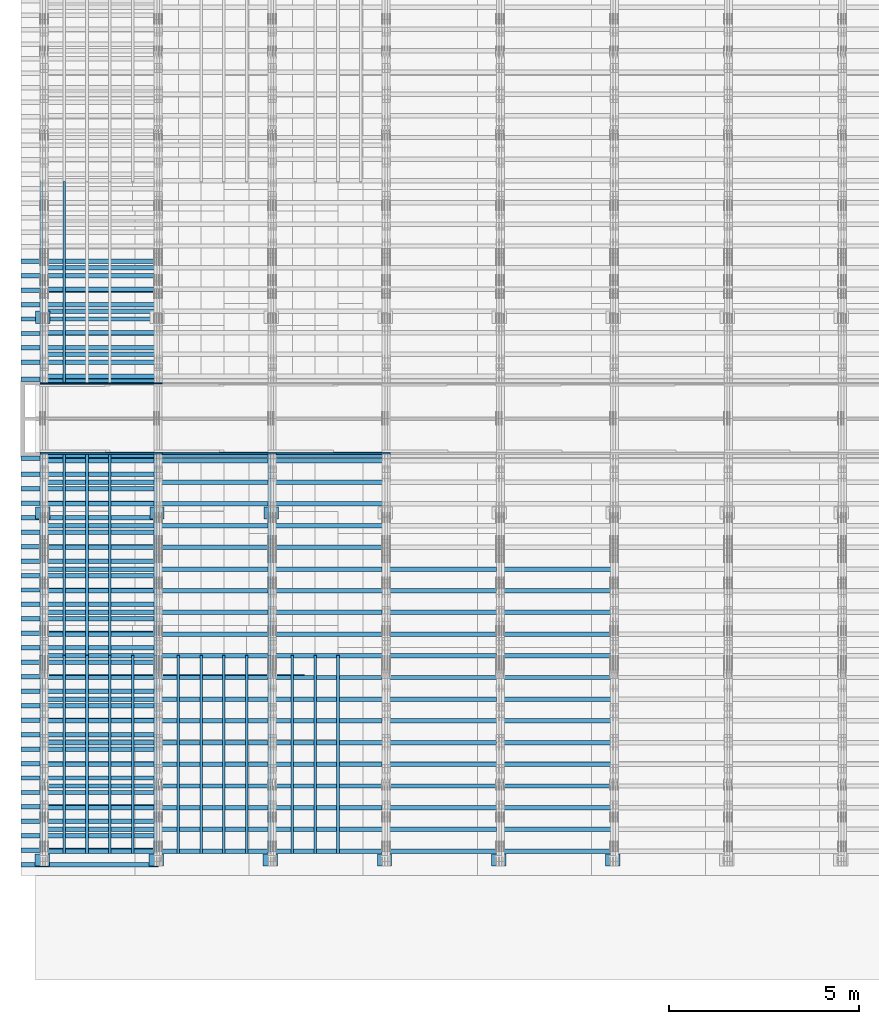
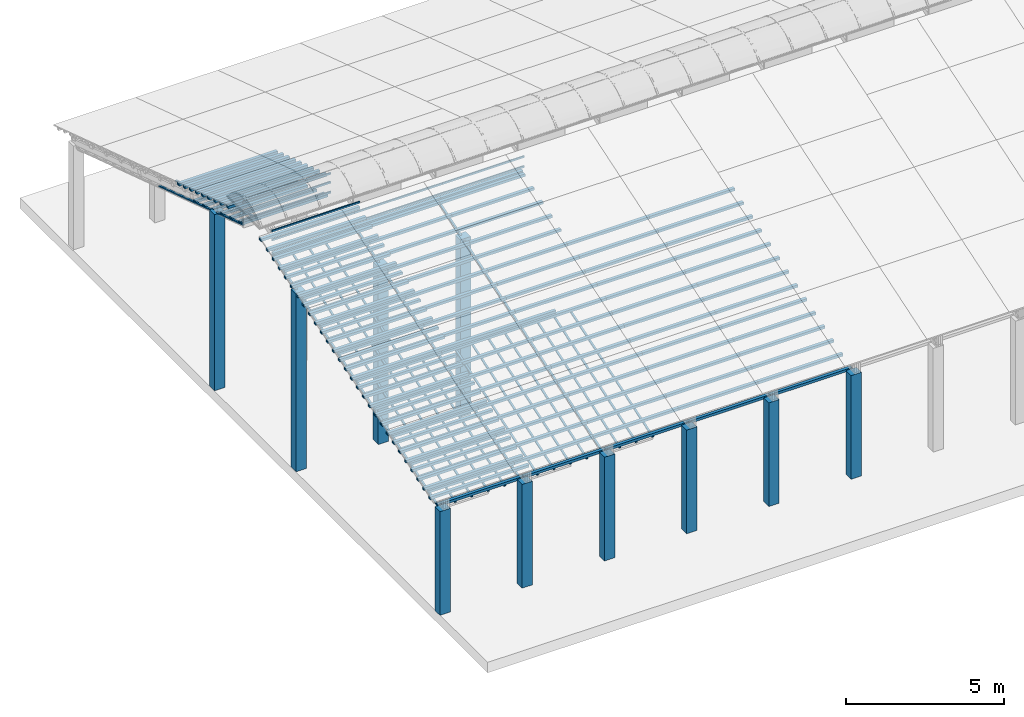
# One storey, part 1 of 385: 175 columns.
"""IFC2X3 building model written with IfcOpenShell, lengths in millimetres."""

from ifc_helpers import new_model, entity, si_unit, converted_unit, derived_unit, direction, frame, frame_2d, origin, origin_2d_with_axis, place, context, subcontext, project, spatial, rectangle, extrude, boolean, source, transform, mapped, material, type_object, type_shapes, element, save


model = new_model("IFC2X3")

# Units and contexts
model_context = context("Model", 3, precision=0.01, world=origin(), true_north=direction((6.12303176911189e-17, 1.0)))
body_context = subcontext(model_context, "Body", "Model", "MODEL_VIEW")
ifc_project = project(units=[si_unit("LENGTHUNIT", "METRE", prefix="MILLI"), si_unit("AREAUNIT", "SQUARE_METRE"), si_unit("VOLUMEUNIT", "CUBIC_METRE"), converted_unit("PLANEANGLEUNIT", "DEGREE", entity("IfcRatioMeasure", 0.0174532925199433), si_unit("PLANEANGLEUNIT", "RADIAN"), dimensions=[0, 0, 0, 0, 0, 0, 0]), si_unit("MASSUNIT", "GRAM", prefix="KILO"), derived_unit("MASSDENSITYUNIT", [(si_unit("MASSUNIT", "GRAM", prefix="KILO"), 1), (si_unit("LENGTHUNIT", "METRE"), -3)]), si_unit("TIMEUNIT", "SECOND"), si_unit("FREQUENCYUNIT", "HERTZ"), si_unit("THERMODYNAMICTEMPERATUREUNIT", "DEGREE_CELSIUS"), derived_unit("THERMALTRANSMITTANCEUNIT", [(si_unit("MASSUNIT", "GRAM", prefix="KILO"), 1), (si_unit("THERMODYNAMICTEMPERATUREUNIT", "KELVIN"), -1), (si_unit("TIMEUNIT", "SECOND"), -3)]), derived_unit("VOLUMETRICFLOWRATEUNIT", [(si_unit("LENGTHUNIT", "METRE"), 3), (si_unit("TIMEUNIT", "SECOND"), -1)]), si_unit("ELECTRICCURRENTUNIT", "AMPERE"), si_unit("ELECTRICVOLTAGEUNIT", "VOLT"), si_unit("POWERUNIT", "WATT"), si_unit("FORCEUNIT", "NEWTON", prefix="KILO"), si_unit("ILLUMINANCEUNIT", "LUX"), si_unit("LUMINOUSFLUXUNIT", "LUMEN"), si_unit("LUMINOUSINTENSITYUNIT", "CANDELA"), derived_unit("USERDEFINED", [(si_unit("MASSUNIT", "GRAM", prefix="KILO"), -1), (si_unit("LENGTHUNIT", "METRE"), -2), (si_unit("TIMEUNIT", "SECOND"), 3), (si_unit("LUMINOUSFLUXUNIT", "LUMEN"), 1)]), derived_unit("LINEARVELOCITYUNIT", [(si_unit("LENGTHUNIT", "METRE"), 1), (si_unit("TIMEUNIT", "SECOND"), -1)]), si_unit("PRESSUREUNIT", "PASCAL"), derived_unit("USERDEFINED", [(si_unit("LENGTHUNIT", "METRE"), -2), (si_unit("MASSUNIT", "GRAM", prefix="KILO"), 1), (si_unit("TIMEUNIT", "SECOND"), -2)])], contexts=[model_context])

# Site, building, storey
site_placement = place(None, origin())
site = spatial("IfcSite", under=ifc_project, at=site_placement, CompositionType="ELEMENT")
building_placement = place(site_placement, origin())
building = spatial("IfcBuilding", under=site, at=building_placement, CompositionType="ELEMENT")
storey_placement = place(building_placement, origin())
storey = spatial("IfcBuildingStorey", under=building, at=storey_placement, Name="Default", CompositionType="ELEMENT", Elevation=0.0)

# Columns
ifc_material_1 = material(Name="2")
column_type_1 = type_object("IfcColumnType", Name="100x70", PredefinedType="COLUMN")
shared_shape_1 = source(origin(), body_context, "Body", "CSG", [
    boolean("DIFFERENCE", extrude(rectangle(XDim=3612.2975905123, YDim=116.736841236773, at=origin_2d_with_axis()), frame((1806.14879525615, -145.11006420193, -28.6286403914129)), (0.0, 0.0, 1.0), 97.4756555803792), extrude(rectangle(XDim=70.0000000018648, YDim=100.00000000027, at=frame_2d((0.0, 3.5527136788005e-15), x_axis=(0.0, 1.0))), frame((0.0, -145.11006420193, 20.1091873987768), z_axis=(-1.0, 0.0, 0.0), x_axis=(0.0, -0.951056516293611, -0.309016994379696)), (0.0, 0.0, -1.0), 3612.2975905123)),
])
type_shapes(column_type_1, [shared_shape_1])
column_1_placement = place(storey_placement, frame((-325.26764333654, 3122.01548150912, 628.753486115588)))
element("IfcColumn", 1, at=column_1_placement, inside=storey, type_object=column_type_1, material=ifc_material_1, Name="H_28_35_gradi:100x70", ObjectType="H_28_35_gradi:100x70", context=body_context, shape_type="MappedRepresentation", body=[
    mapped(shared_shape_1, transform((0.0, 0.0, 0.0), scale=1.0)),
])
for number, where, name in (
    (2, (-325.267643336539, 3502.43808802719, 752.360283865566), "H_28_35_gradi:100x70"),
    (3, (-325.267643336538, 3882.86069454525, 875.967081615544), "H_28_35_gradi:100x70"),
    (4, (-325.267643336538, 4263.28330106331, 999.573879365521), "H_28_35_gradi:100x70"),
    (5, (-325.267643336537, 4643.70590758137, 1123.1806771155), "H_28_35_gradi:100x70"),
    (6, (-325.267643336537, 5024.12851409943, 1246.78747486548), "H_28_35_gradi:100x70"),
    (7, (-325.267643336536, 5404.55112061749, 1370.39427261545), "H_28_35_gradi:100x70"),
    (8, (-325.267643336535, 5784.97372713556, 1494.00107036543), "H_28_35_gradi:100x70"),
    (9, (-325.267643336535, 6165.39633365362, 1617.60786811541), "H_28_35_gradi:100x70"),
    (10, (-325.267643336534, 6545.81894017168, 1741.21466586539), "H_28_35_gradi:100x70"),
    (11, (-325.267643336534, 6926.24154668974, 1864.82146361537), "H_28_35_gradi:100x70"),
    (12, (-325.267643336533, 7306.6641532078, 1988.42826136534), "H_28_35_gradi:100x70"),
    (13, (-325.267643336532, 7687.08675972586, 2112.03505911532), "H_28_35_gradi:100x70"),
    (14, (-325.267643336531, 8447.93197276199, 2359.24865461528), "H_28_35_gradi:100x70"),
    (15, (-325.267643336531, 8828.35457928005, 2482.85545236525), "H_28_35_gradi:100x70"),
    (16, (-325.26764333653, 9208.77718579811, 2606.46225011523), "H_28_35_gradi:100x70"),
    (17, (-325.267643336529, 9589.19979231617, 2730.06904786521), "H_28_35_gradi:100x70"),
    (18, (-325.267643336529, 9969.62239883423, 2853.67584561518), "H_28_35_gradi:100x70"),
    (19, (-325.267643336528, 10350.0450053523, 2977.28264336516), "H_28_35_gradi:100x70"),
    (20, (-325.267643336528, 10730.4676118704, 3100.88944111514), "H_28_35_gradi:100x70"),
    (21, (-325.267643336527, 11110.8902183884, 3224.49623886512), "H_28_35_gradi:100x70"),
    (22, (-325.267643336527, 11491.3128249065, 3348.1030366151), "H_28_35_gradi:100x70"),
    (23, (-325.267643336526, 11871.7354314245, 3471.70983436507), "H_28_35_gradi:100x70"),
    (24, (-325.267643336526, 12252.1580379426, 3595.31663211505), "H_28_35_gradi:100x70"),
    (25, (-325.267643336525, 12632.5806444607, 3718.92342986503), "H_28_35_gradi:100x70"),
    (26, (-325.267643336525, 13013.0032509787, 3842.53022761501), "H_28_35_gradi:100x70"),
    (27, (-325.267643336524, 13393.4258574968, 3966.13702536498), "H_28_35_gradi:100x70"),
    (28, (-325.267643336524, 13811.7416435834, 4102.05606350967), "H_28_35_gradi:100x70"),
):
    element("IfcColumn", number, at=place(building_placement, frame(where)), inside=storey, type_object=column_type_1, material=ifc_material_1, Name=name, ObjectType="H_28_35_gradi:100x70", context=body_context, shape_type="MappedRepresentation", body=[
        mapped(shared_shape_1, transform((0.0, 0.0, 0.0), scale=1.0)),
    ])
ifc_material_2 = material()
column_type_2 = type_object("IfcColumnType", Name="200x200", PredefinedType="COLUMN")
shared_shape_2 = source(origin(), body_context, "Body", "SweptSolid", [
    extrude(rectangle(XDim=379.999999999997, YDim=320.000000000004, at=origin_2d_with_axis()), frame((160.0, 300.0, -4000.0), z_axis=(0.0, 0.0, 1.0), x_axis=(0.0, -1.0, 0.0)), (0.0, 0.0, 1.0), 4000.0),
])
type_shapes(column_type_2, [shared_shape_2])
for number, where, z_axis, x_axis, name in (
    (29, (535.0, 2940.0, 0.0), (0.0, 0.0, 1.0), (0.0, 1.0, 0.0), "V:200x200"),
    (30, (3535.0, 2940.0, 0.0), (0.0, 0.0, 1.0), (0.0, 1.0, 0.0), "V:200x200"),
    (31, (6535.0, 2940.0, 0.0), (0.0, 0.0, 1.0), (0.0, 1.0, 0.0), "V:200x200"),
    (32, (9535.0, 2940.0, 0.0), (0.0, 0.0, 1.0), (0.0, 1.0, 0.0), "V:200x200"),
    (33, (12535.0, 2940.0, 0.0), (0.0, 0.0, 1.0), (0.0, 1.0, 0.0), "V:200x200"),
    (34, (15535.0, 2940.0, 0.0), (0.0, 0.0, 1.0), (0.0, 1.0, 0.0), "V:200x200"),
):
    element("IfcColumn", number, at=place(storey_placement, frame(where, z_axis=z_axis, x_axis=x_axis)), inside=storey, type_object=column_type_2, material=ifc_material_2, Name=name, ObjectType="V:200x200", context=body_context, shape_type="MappedRepresentation", body=[
        mapped(shared_shape_2, transform((0.0, 0.0, 0.0), scale=1.0)),
    ])
column_type_3 = type_object("IfcColumnType", Name="200x200", PredefinedType="COLUMN")
shared_shape_3 = source(origin(), body_context, "Body", "SweptSolid", [
    extrude(rectangle(XDim=379.999999999997, YDim=320.000000000004, at=origin_2d_with_axis()), frame((160.0, 300.0, -4000.0), z_axis=(0.0, 0.0, 1.0), x_axis=(0.0, -1.0, 0.0)), (0.0, 0.0, 1.0), 6794.3),
])
type_shapes(column_type_3, [shared_shape_3])
column_2_placement = place(storey_placement, frame((550.0, 17220.0, 0.0), z_axis=(0.0, 0.0, 1.0), x_axis=(0.0, 1.0, 0.0)))
element("IfcColumn", 35, at=column_2_placement, inside=storey, type_object=column_type_3, material=ifc_material_2, Name="V:200x200", ObjectType="V:200x200", context=body_context, shape_type="MappedRepresentation", body=[
    mapped(shared_shape_3, transform((0.0, 0.0, 0.0), scale=1.0)),
])
column_type_4 = type_object("IfcColumnType", Name="200x200", PredefinedType="COLUMN")
shared_shape_4 = source(origin(), body_context, "Body", "SweptSolid", [
    extrude(rectangle(XDim=379.999999999997, YDim=320.000000000004, at=origin_2d_with_axis()), frame((160.0, 300.0, -4000.0), z_axis=(0.0, 0.0, 1.0), x_axis=(0.0, -1.0, 0.0)), (0.0, 0.0, 1.0), 6849.5),
])
type_shapes(column_type_4, [shared_shape_4])
for number, where, z_axis, x_axis, name in (
    (36, (550.0, 12070.0, 0.0), (0.0, 0.0, 1.0), (0.0, 1.0, 0.0), "V:200x200"),
    (37, (3550.0, 12070.0, 0.0), (0.0, 0.0, 1.0), (0.0, 1.0, 0.0), "V:200x200"),
    (38, (6550.0, 12070.0, 0.0), (0.0, 0.0, 1.0), (0.0, 1.0, 0.0), "V:200x200"),
):
    element("IfcColumn", number, at=place(storey_placement, frame(where, z_axis=z_axis, x_axis=x_axis)), inside=storey, type_object=column_type_4, material=ifc_material_2, Name=name, ObjectType="V:200x200", context=body_context, shape_type="MappedRepresentation", body=[
        mapped(shared_shape_4, transform((0.0, 0.0, 0.0), scale=1.0)),
    ])
column_type_5 = type_object("IfcColumnType", Name="100x70", PredefinedType="COLUMN")
shared_shape_5 = source(origin(), body_context, "Body", "CSG", [
    boolean("DIFFERENCE", extrude(rectangle(XDim=7454.74469050826, YDim=116.736841236773, at=origin_2d_with_axis()), frame((3727.37234525413, -145.11006420193, -28.6286403914129)), (0.0, 0.0, 1.0), 97.4756555803793), extrude(rectangle(XDim=70.0000000018648, YDim=100.00000000027, at=frame_2d((0.0, 3.5527136788005e-15), x_axis=(0.0, 1.0))), frame((0.0, -145.11006420193, 20.1091873987768), z_axis=(-1.0, 0.0, 0.0), x_axis=(0.0, -0.951056516293611, -0.309016994379696)), (0.0, 0.0, -1.0), 7454.74469050826)),
])
type_shapes(column_type_5, [shared_shape_5])
column_3_placement = place(building_placement, frame((-325.267643336532, 8067.50936624392, 2235.6418568653)))
element("IfcColumn", 39, at=column_3_placement, inside=storey, type_object=column_type_5, material=ifc_material_1, Name="H_28_35_gradi:100x70", ObjectType="H_28_35_gradi:100x70", context=body_context, shape_type="MappedRepresentation", body=[
    mapped(shared_shape_5, transform((0.0, 0.0, 0.0), scale=1.0)),
])
column_type_6 = type_object("IfcColumnType", Name="100x70", PredefinedType="COLUMN")
shared_shape_6 = source(origin(), body_context, "Body", "CSG", [
    boolean("DIFFERENCE", extrude(rectangle(XDim=3612.2975905123, YDim=116.736841236773, at=origin_2d_with_axis()), frame((1806.14879525615, 145.11006420193, -28.6286403914129)), (0.0, 0.0, 1.0), 97.4756555803792), extrude(rectangle(XDim=70.0000000018648, YDim=100.00000000027, at=frame_2d((0.0, 3.5527136788005e-15), x_axis=(0.0, 1.0))), frame((3612.2975905123, 145.11006420193, 20.1091873987768), z_axis=(1.0, 0.0, 0.0), x_axis=(0.0, 0.951056516293611, -0.309016994379696)), (0.0, 0.0, -1.0), 3612.2975905123)),
])
type_shapes(column_type_6, [shared_shape_6])
for number, where, name in (
    (40, (-325.267643336515, 18709.5326465873, 3100.88944111514), "H_28_35_gradi:100x70"),
    (41, (-325.267643336516, 18329.1100400692, 3224.49623886512), "H_28_35_gradi:100x70"),
    (42, (-325.267643336516, 17948.6874335511, 3348.1030366151), "H_28_35_gradi:100x70"),
    (43, (-325.267643336517, 17568.2648270331, 3471.70983436507), "H_28_35_gradi:100x70"),
    (44, (-325.267643336518, 17187.842220515, 3595.31663211505), "H_28_35_gradi:100x70"),
    (45, (-325.267643336518, 16807.419613997, 3718.92342986503), "H_28_35_gradi:100x70"),
    (46, (-325.267643336519, 16426.9970074789, 3842.53022761501), "H_28_35_gradi:100x70"),
    (47, (-325.26764333652, 16046.5744009608, 3966.13702536498), "H_28_35_gradi:100x70"),
    (48, (-325.26764333652, 15605.5438149296, 4109.43654940766), "H_28_35_gradi:100x70"),
):
    element("IfcColumn", number, at=place(storey_placement, frame(where)), inside=storey, type_object=column_type_6, material=ifc_material_1, Name=name, ObjectType="H_28_35_gradi:100x70", context=body_context, shape_type="MappedRepresentation", body=[
        mapped(shared_shape_6, transform((0.0, 0.0, 0.0), scale=1.0)),
    ])
column_type_7 = type_object("IfcColumnType", Name="100x70", PredefinedType="COLUMN")
shared_shape_7 = source(origin(), body_context, "Body", "CSG", [
    boolean("DIFFERENCE", extrude(rectangle(XDim=3112.0299471758, YDim=116.736841236773, at=origin_2d_with_axis()), frame((1556.0149735879, 145.11006420193, -28.6286403914128)), (0.0, 0.0, 1.0), 97.4756555803792), extrude(rectangle(XDim=70.0000000018648, YDim=100.00000000027, at=frame_2d((0.0, 3.5527136788005e-15), x_axis=(0.0, 1.0))), frame((3112.0299471758, 145.11006420193, 20.1091873987768), z_axis=(1.0, 0.0, 0.0), x_axis=(0.0, 0.951056516293611, -0.309016994379696)), (0.0, 0.0, -1.0), 3112.0299471758)),
])
type_shapes(column_type_7, [shared_shape_7])
for number, where, name in (
    (49, (175.0, 18538.2806880791, 2372.38724037744), "H_28_35_gradi:100x70"),
    (50, (175.0, 17967.6467783021, 2557.79743700247), "H_28_35_gradi:100x70"),
    (51, (175.0, 17397.012868525, 2743.20763362749), "H_28_35_gradi:100x70"),
    (52, (175.0, 16826.3789587479, 2928.61783025252), "H_28_35_gradi:100x70"),
    (53, (175.0, 16255.7450489708, 3114.02802687754), "H_28_35_gradi:100x70"),
    (54, (175.0, 15685.1111391938, 3299.43822350257), "H_28_35_gradi:100x70"),
    (55, (175.0, 15551.9632269124, 3342.70060271507), "H_28_35_gradi:100x70"),
):
    element("IfcColumn", number, at=place(building_placement, frame(where)), inside=storey, type_object=column_type_7, material=ifc_material_1, Name=name, ObjectType="H_28_35_gradi:100x70", context=body_context, shape_type="MappedRepresentation", body=[
        mapped(shared_shape_7, transform((0.0, 0.0, 0.0), scale=1.0)),
    ])
column_type_8 = type_object("IfcColumnType", Name="45x70", PredefinedType="COLUMN")
shared_shape_8 = source(origin(), body_context, "Body", "SweptSolid", [
    extrude(rectangle(XDim=5592.10619540062, YDim=70.0, at=frame_2d((0.0, -6.82121026329696e-13), x_axis=(0.0, 1.0))), frame((2659.20451847513, -237.823014276398, 864.027924364111), z_axis=(-0.309016994374947, 0.0, 0.951056516295154), x_axis=(0.0, 1.0, 0.0)), (0.0, 0.0, 1.0), 44.9999999999777),
])
type_shapes(column_type_8, [shared_shape_8])
column_4_placement = place(building_placement, frame((447.82301427638, 20941.2050318427, 1574.77111996836), z_axis=(0.0, 0.0, 1.0), x_axis=(0.0, -1.0, 0.0)))
element("IfcColumn", 56, at=column_4_placement, inside=storey, type_object=column_type_8, material=ifc_material_1, Name="H:45x70", ObjectType="H:45x70", context=body_context, shape_type="MappedRepresentation", body=[
    mapped(shared_shape_8, transform((0.0, 0.0, 0.0), scale=1.0)),
])
column_5_placement = place(storey_placement, frame((1047.82301427638, 20941.2050318427, 1574.77111996836), z_axis=(0.0, 0.0, 1.0), x_axis=(0.0, -1.0, 0.0)))
element("IfcColumn", 57, at=column_5_placement, inside=storey, type_object=column_type_8, material=ifc_material_1, Name="H:45x70", ObjectType="H:45x70", context=body_context, shape_type="MappedRepresentation", body=[
    mapped(shared_shape_8, transform((0.0, 0.0, 0.0), scale=1.0)),
])
column_type_9 = type_object("IfcColumnType", Name="100x70", PredefinedType="COLUMN")
shared_shape_9 = source(origin(), body_context, "Body", "CSG", [
    boolean("DIFFERENCE", extrude(rectangle(XDim=3112.0299471758, YDim=116.736841236773, at=origin_2d_with_axis()), frame((1556.0149735879, -145.11006420193, -28.6286403914128)), (0.0, 0.0, 1.0), 97.4756555803792), extrude(rectangle(XDim=70.0000000018648, YDim=100.00000000027, at=frame_2d((0.0, 3.5527136788005e-15), x_axis=(0.0, 1.0))), frame((0.0, -145.11006420193, 20.1091873987768), z_axis=(-1.0, 0.0, 0.0), x_axis=(0.0, -0.951056516293611, -0.309016994379696)), (0.0, 0.0, -1.0), 3112.0299471758)),
])
type_shapes(column_type_9, [shared_shape_9])
for number, where, name in (
    (58, (175.0, 3483.47831537063, -37.9453157522206), "H_28_35_gradi:100x70"),
    (59, (175.0, 4054.11222514638, 147.464880876897), "H_28_35_gradi:100x70"),
    (60, (175.0, 4624.74613492336, 332.8750775022), "H_28_35_gradi:100x70"),
    (61, (175.0, 5195.38004470045, 518.285274127168), "H_28_35_gradi:100x70"),
    (62, (175.0, 5766.01395447752, 703.695470752224), "H_28_35_gradi:100x70"),
    (63, (175.0, 6336.64786425459, 889.105667377245), "H_28_35_gradi:100x70"),
    (64, (175.0, 6907.28177403167, 1074.51586400227), "H_28_35_gradi:100x70"),
    (65, (175.0, 7477.91568380874, 1259.92606062729), "H_28_35_gradi:100x70"),
    (66, (175.0, 8048.54959358582, 1445.33625725232), "H_28_35_gradi:100x70"),
    (67, (175.0, 8619.18350336289, 1630.74645387734), "H_28_35_gradi:100x70"),
    (68, (175.0, 9189.81741313997, 1816.15665050237), "H_28_35_gradi:100x70"),
    (69, (175.0, 9760.45132291704, 2001.56684712739), "H_28_35_gradi:100x70"),
    (70, (175.0, 10331.0852326941, 2186.97704375242), "H_28_35_gradi:100x70"),
    (71, (175.0, 10901.7191424712, 2372.38724037744), "H_28_35_gradi:100x70"),
    (72, (175.0, 11472.3530522483, 2557.79743700247), "H_28_35_gradi:100x70"),
    (73, (175.0, 12042.9869620253, 2743.20763362749), "H_28_35_gradi:100x70"),
    (74, (175.0, 12613.6208718024, 2928.61783025252), "H_28_35_gradi:100x70"),
    (75, (175.0, 13184.2547815795, 3114.02802687754), "H_28_35_gradi:100x70"),
    (76, (175.0, 13754.8886913566, 3299.43822350257), "H_28_35_gradi:100x70"),
    (77, (175.0, 13888.0366036379, 3342.70060271507), "H_28_35_gradi:100x70"),
    (78, (3175.0, 3483.47831537062, -37.9453157522206), "H_28_35_gradi:100x70"),
    (79, (3175.0, 4054.11222514637, 147.464880876897), "H_28_35_gradi:100x70"),
    (80, (3175.0, 4624.74613492335, 332.8750775022), "H_28_35_gradi:100x70"),
    (81, (3175.0, 5195.38004470044, 518.285274127168), "H_28_35_gradi:100x70"),
    (82, (3175.0, 5766.01395447751, 703.695470752224), "H_28_35_gradi:100x70"),
    (83, (3175.0, 6336.64786425458, 889.105667377245), "H_28_35_gradi:100x70"),
    (84, (3175.0, 6907.28177403166, 1074.51586400227), "H_28_35_gradi:100x70"),
    (85, (3175.0, 7477.91568380873, 1259.92606062729), "H_28_35_gradi:100x70"),
    (86, (3175.0, 8048.54959358581, 1445.33625725232), "H_28_35_gradi:100x70"),
    (87, (3175.0, 8619.18350336288, 1630.74645387734), "H_28_35_gradi:100x70"),
    (88, (3175.0, 9189.81741313996, 1816.15665050237), "H_28_35_gradi:100x70"),
    (89, (3175.0, 9760.45132291703, 2001.56684712739), "H_28_35_gradi:100x70"),
    (90, (3175.0, 10331.0852326941, 2186.97704375242), "H_28_35_gradi:100x70"),
    (91, (3175.0, 10901.7191424712, 2372.38724037744), "H_28_35_gradi:100x70"),
    (92, (3175.0, 11472.3530522482, 2557.79743700247), "H_28_35_gradi:100x70"),
    (93, (3175.0, 12042.9869620253, 2743.20763362749), "H_28_35_gradi:100x70"),
    (94, (3175.0, 12613.6208718024, 2928.61783025252), "H_28_35_gradi:100x70"),
    (95, (3175.0, 13184.2547815795, 3114.02802687754), "H_28_35_gradi:100x70"),
    (96, (3175.0, 13754.8886913565, 3299.43822350257), "H_28_35_gradi:100x70"),
    (97, (3175.0, 13888.0366036379, 3342.70060271507), "H_28_35_gradi:100x70"),
    (98, (6175.0, 3483.47831537061, -37.9453157522206), "H_28_35_gradi:100x70"),
    (99, (6175.0, 4054.11222514636, 147.464880876897), "H_28_35_gradi:100x70"),
    (100, (6175.0, 4624.74613492334, 332.8750775022), "H_28_35_gradi:100x70"),
    (101, (6175.0, 5195.38004470044, 518.285274127168), "H_28_35_gradi:100x70"),
    (102, (6175.0, 5766.0139544775, 703.695470752224), "H_28_35_gradi:100x70"),
    (103, (6175.0, 6336.64786425457, 889.105667377245), "H_28_35_gradi:100x70"),
    (104, (6175.0, 6907.28177403165, 1074.51586400227), "H_28_35_gradi:100x70"),
    (105, (6175.0, 7477.91568380872, 1259.92606062729), "H_28_35_gradi:100x70"),
    (106, (6175.0, 8048.5495935858, 1445.33625725232), "H_28_35_gradi:100x70"),
    (107, (6175.0, 8619.18350336287, 1630.74645387734), "H_28_35_gradi:100x70"),
    (108, (6175.0, 9189.81741313995, 1816.15665050237), "H_28_35_gradi:100x70"),
    (109, (6175.0, 9760.45132291702, 2001.56684712739), "H_28_35_gradi:100x70"),
    (110, (6175.0, 10331.0852326941, 2186.97704375242), "H_28_35_gradi:100x70"),
    (111, (6175.0, 10901.7191424712, 2372.38724037744), "H_28_35_gradi:100x70"),
    (112, (6175.0, 11472.3530522482, 2557.79743700247), "H_28_35_gradi:100x70"),
    (113, (6175.0, 12042.9869620253, 2743.20763362749), "H_28_35_gradi:100x70"),
    (114, (6175.0, 12613.6208718024, 2928.61783025252), "H_28_35_gradi:100x70"),
    (115, (6175.0, 13184.2547815795, 3114.02802687754), "H_28_35_gradi:100x70"),
    (116, (6175.0, 13754.8886913565, 3299.43822350257), "H_28_35_gradi:100x70"),
    (117, (6175.0, 13888.0366036379, 3342.70060271507), "H_28_35_gradi:100x70"),
    (118, (9175.0, 3483.4783153706, -37.9453157522206), "H_28_35_gradi:100x70"),
    (119, (9175.0, 4054.11222514635, 147.464880876897), "H_28_35_gradi:100x70"),
    (120, (9175.0, 4624.74613492333, 332.8750775022), "H_28_35_gradi:100x70"),
    (121, (9175.0, 5195.38004470043, 518.285274127168), "H_28_35_gradi:100x70"),
    (122, (9175.0, 5766.01395447749, 703.695470752224), "H_28_35_gradi:100x70"),
    (123, (9175.0, 6336.64786425456, 889.105667377245), "H_28_35_gradi:100x70"),
    (124, (9175.0, 6907.28177403164, 1074.51586400227), "H_28_35_gradi:100x70"),
    (125, (9175.0, 7477.91568380871, 1259.92606062729), "H_28_35_gradi:100x70"),
    (126, (9175.0, 8048.54959358579, 1445.33625725232), "H_28_35_gradi:100x70"),
    (127, (9175.0, 8619.18350336286, 1630.74645387734), "H_28_35_gradi:100x70"),
    (128, (9175.0, 9189.81741313994, 1816.15665050237), "H_28_35_gradi:100x70"),
    (129, (9175.0, 9760.45132291701, 2001.56684712739), "H_28_35_gradi:100x70"),
    (130, (9175.0, 10331.0852326941, 2186.97704375242), "H_28_35_gradi:100x70"),
    (131, (9175.0, 10901.7191424712, 2372.38724037744), "H_28_35_gradi:100x70"),
    (132, (12175.0, 3483.47831537059, -37.9453157522206), "H_28_35_gradi:100x70"),
    (133, (12175.0, 4054.11222514634, 147.464880876897), "H_28_35_gradi:100x70"),
    (134, (12175.0, 4624.74613492332, 332.8750775022), "H_28_35_gradi:100x70"),
    (135, (12175.0, 5195.38004470042, 518.285274127168), "H_28_35_gradi:100x70"),
    (136, (12175.0, 5766.01395447748, 703.695470752224), "H_28_35_gradi:100x70"),
    (137, (12175.0, 6336.64786425455, 889.105667377245), "H_28_35_gradi:100x70"),
    (138, (12175.0, 6907.28177403163, 1074.51586400227), "H_28_35_gradi:100x70"),
    (139, (12175.0, 7477.9156838087, 1259.92606062729), "H_28_35_gradi:100x70"),
    (140, (12175.0, 8048.54959358578, 1445.33625725232), "H_28_35_gradi:100x70"),
    (141, (12175.0, 8619.18350336285, 1630.74645387734), "H_28_35_gradi:100x70"),
    (142, (12175.0, 9189.81741313993, 1816.15665050237), "H_28_35_gradi:100x70"),
    (143, (12175.0, 9760.451322917, 2001.56684712739), "H_28_35_gradi:100x70"),
    (144, (12175.0, 10331.0852326941, 2186.97704375242), "H_28_35_gradi:100x70"),
    (145, (12175.0, 10901.7191424712, 2372.38724037744), "H_28_35_gradi:100x70"),
):
    element("IfcColumn", number, at=place(storey_placement, frame(where)), inside=storey, type_object=column_type_9, material=ifc_material_1, Name=name, ObjectType="H_28_35_gradi:100x70", context=body_context, shape_type="MappedRepresentation", body=[
        mapped(shared_shape_9, transform((0.0, 0.0, 0.0), scale=1.0)),
    ])
column_type_10 = type_object("IfcColumnType", Name="45x70", PredefinedType="COLUMN")
shared_shape_10 = source(origin(), body_context, "Body", "SweptSolid", [
    extrude(rectangle(XDim=5484.52420681414, YDim=70.0, at=frame_2d((9.09494701772928e-13, -3.19744231092045e-14), x_axis=(1.0, 0.0))), frame((2608.04624283455, 237.823014276398, 847.405592983174), z_axis=(-0.309016994374947, 0.0, 0.951056516295154), x_axis=(-0.951056516295154, 0.0, -0.309016994374947)), (0.0, 0.0, 1.0), 44.9999999999777),
])
type_shapes(column_type_10, [shared_shape_10])
for number, where, z_axis, x_axis, name in (
    (146, (447.823014276352, 3283.5743142486, -119.756735629718), (0.0, 0.0, 1.0), (0.0, 1.0, 0.0), "H:45x70"),
    (147, (1047.82301427635, 3283.5743142486, -119.756735629718), (0.0, 0.0, 1.0), (0.0, 1.0, 0.0), "H:45x70"),
    (148, (1647.82301427635, 3283.5743142486, -119.756735629718), (0.0, 0.0, 1.0), (0.0, 1.0, 0.0), "H:45x70"),
    (149, (2247.82301427635, 3283.5743142486, -119.756735629718), (0.0, 0.0, 1.0), (0.0, 1.0, 0.0), "H:45x70"),
    (150, (3447.82301427635, 3283.57431424859, -119.756735629718), (0.0, 0.0, 1.0), (0.0, 1.0, 0.0), "H:45x70"),
    (151, (4047.82301427635, 3283.57431424859, -119.756735629718), (0.0, 0.0, 1.0), (0.0, 1.0, 0.0), "H:45x70"),
    (152, (4647.82301427635, 3283.57431424859, -119.756735629718), (0.0, 0.0, 1.0), (0.0, 1.0, 0.0), "H:45x70"),
    (153, (5247.82301427635, 3283.57431424859, -119.756735629718), (0.0, 0.0, 1.0), (0.0, 1.0, 0.0), "H:45x70"),
    (154, (6447.82301427635, 3283.57431424858, -119.756735629718), (0.0, 0.0, 1.0), (0.0, 1.0, 0.0), "H:45x70"),
    (155, (7047.82301427635, 3283.57431424858, -119.756735629718), (0.0, 0.0, 1.0), (0.0, 1.0, 0.0), "H:45x70"),
    (156, (7647.82301427635, 3283.57431424858, -119.756735629718), (0.0, 0.0, 1.0), (0.0, 1.0, 0.0), "H:45x70"),
    (157, (8247.82301427635, 3283.57431424858, -119.756735629718), (0.0, 0.0, 1.0), (0.0, 1.0, 0.0), "H:45x70"),
    (158, (2847.82301427635, 3283.57431424859, -119.756735629716), (0.0, 0.0, 1.0), (0.0, 1.0, 0.0), "H:45x70"),
    (159, (5847.82301427636, 3283.57431424859, -119.75673562972), (0.0, 0.0, 1.0), (0.0, 1.0, 0.0), "H:45x70"),
):
    element("IfcColumn", number, at=place(storey_placement, frame(where, z_axis=z_axis, x_axis=x_axis)), inside=storey, type_object=column_type_10, material=ifc_material_1, Name=name, ObjectType="H:45x70", context=body_context, shape_type="MappedRepresentation", body=[
        mapped(shared_shape_10, transform((0.0, 0.0, 0.0), scale=1.0)),
    ])
column_type_11 = type_object("IfcColumnType", Name="45x70", PredefinedType="COLUMN")
shared_shape_11 = source(origin(), body_context, "Body", "SweptSolid", [
    extrude(rectangle(XDim=5592.10619540062, YDim=70.0, at=frame_2d((0.0, -3.19744231092045e-14), x_axis=(1.0, 0.0))), frame((2659.20451847513, 237.823014276398, 864.027924364111), z_axis=(-0.309016994374947, 0.0, 0.951056516295154), x_axis=(-0.951056516295154, 0.0, -0.309016994374947)), (0.0, 0.0, 1.0), 44.9999999999777),
])
type_shapes(column_type_11, [shared_shape_11])
for number, where, z_axis, x_axis, name in (
    (160, (447.82301427636, 8498.79479870765, 1574.77111996836), (0.0, 0.0, 1.0), (0.0, 1.0, 0.0), "H:45x70"),
    (161, (1047.82301427636, 8498.79479870765, 1574.77111996836), (0.0, 0.0, 1.0), (0.0, 1.0, 0.0), "H:45x70"),
    (162, (1647.82301427636, 8498.79479870765, 1574.77111996836), (0.0, 0.0, 1.0), (0.0, 1.0, 0.0), "H:45x70"),
    (163, (2247.82301427636, 8498.79479870765, 1574.77111996836), (0.0, 0.0, 1.0), (0.0, 1.0, 0.0), "H:45x70"),
    (164, (3447.82301427636, 8498.79479870764, 1574.77111996836), (0.0, 0.0, 1.0), (0.0, 1.0, 0.0), "H:45x70"),
    (165, (6447.82301427636, 8498.79479870763, 1574.77111996836), (0.0, 0.0, 1.0), (0.0, 1.0, 0.0), "H:45x70"),
):
    element("IfcColumn", number, at=place(storey_placement, frame(where, z_axis=z_axis, x_axis=x_axis)), inside=storey, type_object=column_type_11, material=ifc_material_1, Name=name, ObjectType="H:45x70", context=body_context, shape_type="MappedRepresentation", body=[
        mapped(shared_shape_11, transform((0.0, 0.0, 0.0), scale=1.0)),
    ])
column_type_12 = type_object("IfcColumnType", Name="70x45", PredefinedType="COLUMN")
shared_shape_12 = source(origin(), body_context, "Body", "SweptSolid", [
    extrude(rectangle(XDim=45.0, YDim=3207.99969607346, at=frame_2d((-1.59872115546023e-14, 0.0), x_axis=(1.0, 0.0))), frame((1603.99984803673, 250.323014276398, 0.0), z_axis=(0.0, 0.0, 1.0), x_axis=(0.0, -1.0, 0.0)), (0.0, 0.0, 1.0), 69.9999999999776),
])
type_shapes(column_type_12, [shared_shape_12])
column_6_placement = place(storey_placement, frame((3382.99969607345, 15887.8230423367, 3436.65682464217), z_axis=(0.0, 0.0, 1.0), x_axis=(-1.0, 0.0, 0.0)))
element("IfcColumn", 166, at=column_6_placement, inside=storey, type_object=column_type_12, material=ifc_material_1, Name="H1:70x45", ObjectType="H1:70x45", context=body_context, shape_type="MappedRepresentation", body=[
    mapped(shared_shape_12, transform((0.0, 0.0, 0.0), scale=1.0)),
])
for number, where, z_axis, x_axis, name in (
    (167, (3382.99969607345, 15887.8230423367, 3821.65682464217), (0.0, 0.0, 1.0), (-1.0, 0.0, 0.0), "H1:70x45"),
    (168, (3382.99969607345, 15887.8230423367, 4161.65682464218), (0.0, 0.0, 1.0), (-1.0, 0.0, 0.0), "H1:70x45"),
):
    element("IfcColumn", number, at=place(building_placement, frame(where, z_axis=z_axis, x_axis=x_axis)), inside=storey, type_object=column_type_12, material=ifc_material_1, Name=name, ObjectType="H1:70x45", context=body_context, shape_type="MappedRepresentation", body=[
        mapped(shared_shape_12, transform((0.0, 0.0, 0.0), scale=1.0)),
    ])
column_type_13 = type_object("IfcColumnType", Name="70x45", PredefinedType="COLUMN")
shared_shape_13 = source(origin(), body_context, "Body", "SweptSolid", [
    extrude(rectangle(XDim=45.0, YDim=3215.28399061289, at=frame_2d((1.59872115546023e-14, 0.0), x_axis=(1.0, 0.0))), frame((1607.64199530645, -250.323014276398, 0.0), z_axis=(0.0, 0.0, 1.0), x_axis=(0.0, -1.0, 0.0)), (0.0, 0.0, 1.0), 69.9999999999776),
])
type_shapes(column_type_13, [shared_shape_13])
for number, where, z_axis, x_axis, name in (
    (169, (3390.28399061288, 13552.1767882136, 3436.65682464217), (0.0, 0.0, 1.0), (-1.0, 0.0, 0.0), "H1:70x45"),
    (170, (3390.28399061288, 13552.1767882136, 3821.65682464217), (0.0, 0.0, 1.0), (-1.0, 0.0, 0.0), "H1:70x45"),
    (171, (6390.28399061288, 13552.1767882135, 3436.65682464217), (0.0, 0.0, 1.0), (-1.0, 0.0, 0.0), "H1:70x45"),
    (172, (6390.28399061288, 13552.1767882135, 3821.65682464217), (0.0, 0.0, 1.0), (-1.0, 0.0, 0.0), "H1:70x45"),
    (173, (9390.28399061288, 13552.1767882135, 3436.65682464217), (0.0, 0.0, 1.0), (-1.0, 0.0, 0.0), "H1:70x45"),
    (174, (9390.28399061288, 13552.1767882135, 3821.65682464217), (0.0, 0.0, 1.0), (-1.0, 0.0, 0.0), "H1:70x45"),
):
    element("IfcColumn", number, at=place(storey_placement, frame(where, z_axis=z_axis, x_axis=x_axis)), inside=storey, type_object=column_type_13, material=ifc_material_1, Name=name, ObjectType="H1:70x45", context=body_context, shape_type="MappedRepresentation", body=[
        mapped(shared_shape_13, transform((0.0, 0.0, 0.0), scale=1.0)),
    ])
column_7_placement = place(building_placement, frame((3390.28399061288, 13552.1767882136, 4161.65682464217), z_axis=(0.0, 0.0, 1.0), x_axis=(-1.0, 0.0, 0.0)))
element("IfcColumn", 175, at=column_7_placement, inside=storey, type_object=column_type_13, material=ifc_material_1, Name="H1:70x45", ObjectType="H1:70x45", context=body_context, shape_type="MappedRepresentation", body=[
    mapped(shared_shape_13, transform((0.0, 0.0, 0.0), scale=1.0)),
])

save(model, "model.ifc")
